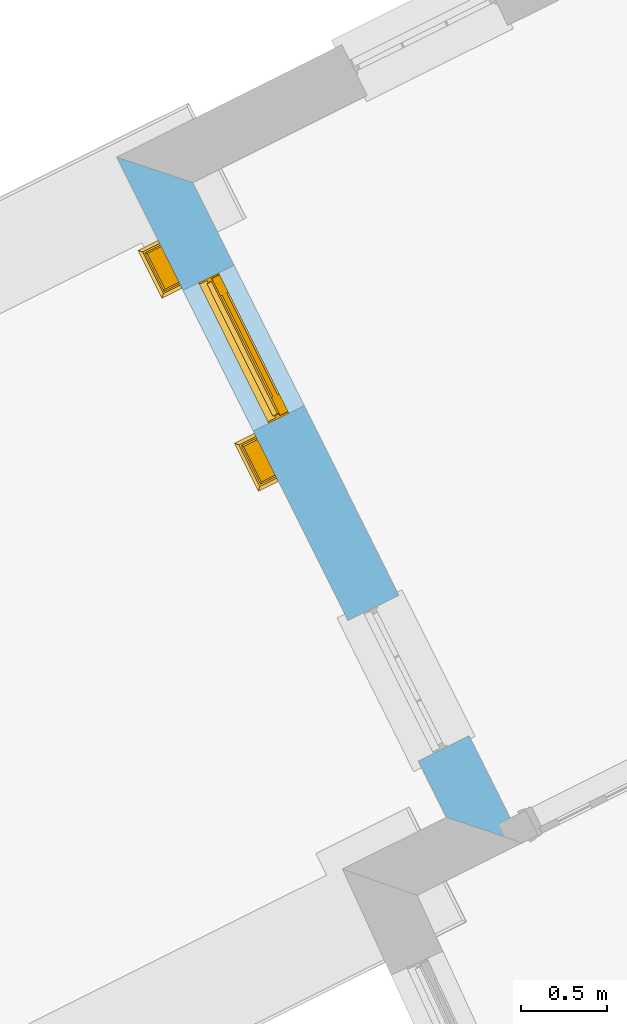
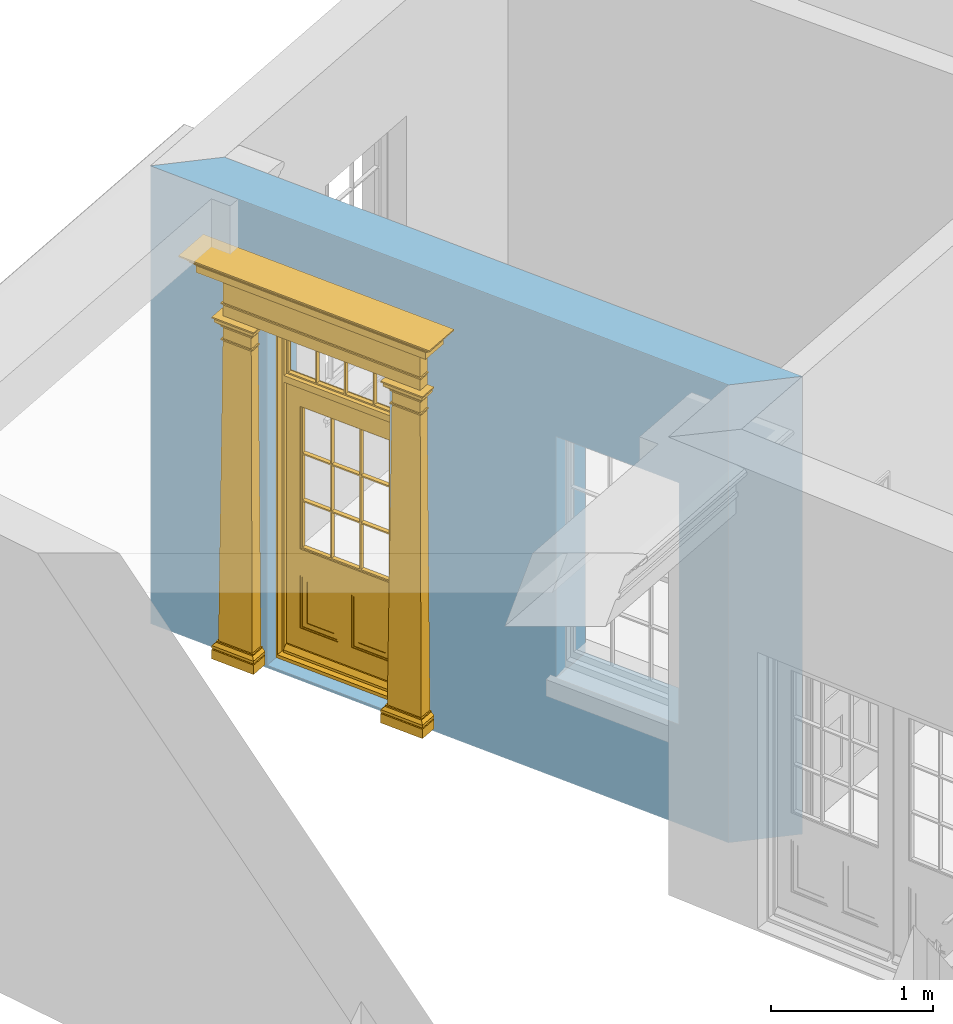
# One storey, part 7 of 10: 1 door, 2 openings, plus 1 element that does not belong to this part.
"""IFC2X3 building model written with IfcOpenShell, lengths in metres."""

import ifcopenshell
import ifcopenshell.guid

model = None  # the IFC model being written
_history = None  # IfcOwnerHistory: only IFC2X3 demands one
_inside = {}  # id of a spatial element -> (the spatial element, [elements in it])
_under = {}  # id of a project, library or spatial element -> (it, [spatial elements below it])
_declared = {}  # id of a project -> (the project, [libraries it declares])
_typed = {}  # id of a type object -> (the type object, [elements of that type])
_made_of = {}  # id of a material, layer set ... -> (it, [elements and type objects made of it])


def new_model(schema):
    """Start an empty IFC model of exactly this schema.

    Asked for "IFC4X3", IfcOpenShell would pick the latest addendum, in which some entities
    have other attributes; the version numbers below select the first issue.
    IFC2X3 requires an IfcOwnerHistory on every rooted entity: one is made here for all.
    """
    global model, _history
    if schema == "IFC4X3":
        model = ifcopenshell.file(schema_version=(4, 3, 0, 0))
    else:
        model = ifcopenshell.file(schema=schema)
    _inside.clear()
    _under.clear()
    _declared.clear()
    _typed.clear()
    _made_of.clear()
    _history = None
    if model.schema == "IFC2X3":
        org = make("IfcOrganization", Name="unknown")
        user = make(
            "IfcPersonAndOrganization",
            ThePerson=make("IfcPerson", FamilyName="unknown"),
            TheOrganization=org,
        )
        app = make(
            "IfcApplication",
            ApplicationDeveloper=org,
            Version="unknown",
            ApplicationFullName="unknown",
            ApplicationIdentifier="unknown",
        )
        _history = make(
            "IfcOwnerHistory",
            OwningUser=user,
            OwningApplication=app,
            ChangeAction="ADDED",
            CreationDate=0,
        )
    return model


def make(cls, **values):
    """One entity of the class cls with the attributes given. An attribute that is None is left unset."""
    return model.create_entity(
        cls, **{name: value for name, value in values.items() if value is not None}
    )


def rooted(cls, **values):
    """An entity with a GlobalId (a new one), such as an element, a storey or a relation."""
    return make(cls, GlobalId=ifcopenshell.guid.new(), OwnerHistory=_history, **values)


def si_unit(unit_type, name, prefix=None):
    """IfcSIUnit, for example si_unit("LENGTHUNIT", "METRE", prefix="MILLI")."""
    return make("IfcSIUnit", UnitType=unit_type, Prefix=prefix, Name=name)


def assignment(units):
    """IfcUnitAssignment: the units of a project."""
    return None if units is None else make("IfcUnitAssignment", Units=units)


def point(xyz):
    """IfcCartesianPoint."""
    return None if xyz is None else make("IfcCartesianPoint", Coordinates=xyz)


def direction(xyz):
    """IfcDirection."""
    return None if xyz is None else make("IfcDirection", DirectionRatios=xyz)


def frame(location, z_axis=None, x_axis=None):
    """IfcAxis2Placement3D, a coordinate frame: its origin and axes. An axis left out is left unset."""
    return make(
        "IfcAxis2Placement3D",
        Location=point(location),
        Axis=direction(z_axis),
        RefDirection=direction(x_axis),
    )


def origin():
    """The frame at (0, 0, 0) with its axes left unset."""
    return frame((0.0, 0.0, 0.0))


def place(relative_to, where):
    """IfcLocalPlacement: puts the frame where relative to a parent placement (None: the world)."""
    return make(
        "IfcLocalPlacement", PlacementRelTo=relative_to, RelativePlacement=where
    )


def context(
    kind, dimensions, precision=None, world=None, true_north=None, identifier=None
):
    """IfcGeometricRepresentationContext, for example the 3D "Model" context."""
    return make(
        "IfcGeometricRepresentationContext",
        ContextIdentifier=identifier,
        ContextType=kind,
        CoordinateSpaceDimension=dimensions,
        Precision=precision,
        WorldCoordinateSystem=world,
        TrueNorth=true_north,
    )


def subcontext(parent, identifier, kind, view, scale=None):
    """IfcGeometricRepresentationSubContext, for example "Body" below "Model"."""
    return make(
        "IfcGeometricRepresentationSubContext",
        ContextIdentifier=identifier,
        ContextType=kind,
        ParentContext=parent,
        TargetScale=scale,
        TargetView=view,
    )


def project(units=None, contexts=None):
    """IfcProject with its units and contexts."""
    return rooted(
        "IfcProject",
        Name="project",
        RepresentationContexts=contexts,
        UnitsInContext=assignment(units),
    )


def spatial(cls, under=None, at=None, **own):
    """A site, building, storey or space (cls), placed at a placement, below another one or the project."""
    s = rooted(cls, ObjectPlacement=at, **own)
    if under is not None:
        _under.setdefault(under.id(), (under, []))[1].append(s)
    return s


def polyline(points):
    """IfcPolyline through the points."""
    return make("IfcPolyline", Points=[point(p) for p in points])


def outline(outer, holes=None, kind="AREA"):
    """IfcArbitraryClosedProfileDef: a profile drawn as a closed curve; with holes, ...WithVoids."""
    if holes is None:
        return make("IfcArbitraryClosedProfileDef", ProfileType=kind, OuterCurve=outer)
    return make(
        "IfcArbitraryProfileDefWithVoids",
        ProfileType=kind,
        OuterCurve=outer,
        InnerCurves=holes,
    )


def extrude(swept, where, along, depth):
    """IfcExtrudedAreaSolid: the profile swept, set in the frame where, extruded along a direction by depth."""
    return make(
        "IfcExtrudedAreaSolid",
        SweptArea=swept,
        Position=where,
        ExtrudedDirection=direction(along),
        Depth=depth,
    )


def faces_of(points, faces, orient=None, outer=None):
    """IfcFace entities. A face is a list of loops; a loop is a list of indices into points, from 0.

    orient and outer hold one flag for each loop. By default every Orientation is true, the
    first loop of a face is its IfcFaceOuterBound and the others are IfcFaceBound.
    """
    made = []
    for i, loops in enumerate(faces):
        bounds = []
        for j, loop in enumerate(loops):
            is_outer = j == 0 if outer is None else outer[i][j]
            bounds.append(
                make(
                    "IfcFaceOuterBound" if is_outer else "IfcFaceBound",
                    Bound=make("IfcPolyLoop", Polygon=[points[k] for k in loop]),
                    Orientation=True if orient is None else orient[i][j],
                )
            )
        made.append(make("IfcFace", Bounds=bounds))
    return made


def faceted_brep(points, faces, orient=None, outer=None, voids=None):
    """IfcFacetedBrep: a solid bounded by flat faces; with voids (closed shells), ...WithVoids."""
    shared = [point(p) for p in points]
    hull = make("IfcClosedShell", CfsFaces=faces_of(shared, faces, orient, outer))
    if voids is None:
        return make("IfcFacetedBrep", Outer=hull)
    return make(
        "IfcFacetedBrepWithVoids",
        Outer=hull,
        Voids=[
            make(cls, CfsFaces=faces_of(shared, fs, o, b)) for cls, fs, o, b in voids
        ],
    )


def shape(context_of_items, identifier, shape_type, items):
    """IfcShapeRepresentation: the items that make up one representation, for example the "Body"."""
    return make(
        "IfcShapeRepresentation",
        ContextOfItems=context_of_items,
        RepresentationIdentifier=identifier,
        RepresentationType=shape_type,
        Items=items,
    )


def material(Name=None, Category=None):
    """IfcMaterial."""
    return make("IfcMaterial", Name=Name, Category=Category)


def layer(
    of_material, thickness, ventilated=None, Name=None, Category=None, Priority=None
):
    """IfcMaterialLayer: one layer of a wall or slab, of a material (None: an air gap)."""
    return make(
        "IfcMaterialLayer",
        Material=of_material,
        LayerThickness=thickness,
        IsVentilated=ventilated,
        Name=Name,
        Category=Category,
        Priority=Priority,
    )


def layer_set(layers, Name=None):
    """IfcMaterialLayerSet."""
    return make("IfcMaterialLayerSet", MaterialLayers=layers, LayerSetName=Name)


def layer_usage(for_layer_set, set_direction, sense, offset, extent=None):
    """IfcMaterialLayerSetUsage: how a layer set lies in its element."""
    return make(
        "IfcMaterialLayerSetUsage",
        ForLayerSet=for_layer_set,
        LayerSetDirection=set_direction,
        DirectionSense=sense,
        OffsetFromReferenceLine=offset,
        ReferenceExtent=extent,
    )


def made_of(thing, what):
    """Note that an element or type object is made of a material, layer set ...; save() writes the relation."""
    if what is not None:
        _made_of.setdefault(what.id(), (what, []))[1].append(thing)
    return thing


def element(
    cls,
    number,
    at=None,
    inside=None,
    cuts=None,
    type_object=None,
    material=None,
    context=None,
    identifier="Body",
    shape_type=None,
    held_by="IfcProductDefinitionShape",
    body=None,
    shapes=None,
    **own,
):
    """One element of the class cls, such as IfcWall. Its Tag is "e" and its number.

    at: its placement. inside: the storey or other place that contains it. cuts: it is an
    opening in that element (IfcRelVoidsElement). A single representation is given by context,
    identifier, shape_type and body (its items); several are given by shapes. held_by: the class
    of the entity that holds the representations. save() writes the other relations.
    """
    e = rooted(cls, Tag="e%d" % number, ObjectPlacement=at, **own)
    if body is not None:
        shapes = [shape(context, identifier, shape_type, body)]
    if shapes is not None:
        e.Representation = make(held_by, Representations=shapes)
    if inside is not None:
        _inside.setdefault(inside.id(), (inside, []))[1].append(e)
    if cuts is not None:
        rooted(
            "IfcRelVoidsElement", RelatingBuildingElement=cuts, RelatedOpeningElement=e
        )
    if type_object is not None:
        _typed.setdefault(type_object.id(), (type_object, []))[1].append(e)
    return made_of(e, material)


def fill(opening, filler):
    """IfcRelFillsElement: the door or window that sits in an opening."""
    return rooted(
        "IfcRelFillsElement",
        RelatingOpeningElement=opening,
        RelatedBuildingElement=filler,
    )


def aggregate(whole, parts):
    """IfcRelAggregates: a whole, such as a stair, and the parts it consists of."""
    return rooted("IfcRelAggregates", RelatingObject=whole, RelatedObjects=parts)


def save(model, path):
    """Write the relations noted so far, then the file.

    IfcRelAggregates (storeys below a building ...), IfcRelContainedInSpatialStructure (elements
    in a storey), IfcRelDefinesByType, IfcRelAssociatesMaterial and IfcRelDeclares: one each for
    every whole, place, type object, material and project.
    """
    for whole, parts in _under.values():
        aggregate(whole, parts)
    for where, things in _inside.values():
        rooted(
            "IfcRelContainedInSpatialStructure",
            RelatedElements=things,
            RelatingStructure=where,
        )
    for kind, things in _typed.values():
        rooted("IfcRelDefinesByType", RelatedObjects=things, RelatingType=kind)
    for what, things in _made_of.values():
        rooted("IfcRelAssociatesMaterial", RelatedObjects=things, RelatingMaterial=what)
    for by, libraries in _declared.values():
        rooted("IfcRelDeclares", RelatingContext=by, RelatedDefinitions=libraries)
    model.write(path)


model = new_model("IFC2X3")

# Units and contexts
model_context = context("Model", 3, world=origin())
body_context = subcontext(model_context, "Body", "Model", "MODEL_VIEW")
ifc_project = project(units=[si_unit("PLANEANGLEUNIT", "RADIAN"), si_unit("MASSUNIT", "GRAM", prefix="KILO"), si_unit("FORCEUNIT", "NEWTON", prefix="KILO"), si_unit("LENGTHUNIT", "METRE")], contexts=[model_context])

# Site, building, storey
site_placement = place(None, origin())
site = spatial("IfcSite", under=ifc_project, at=site_placement, CompositionType="ELEMENT")
building_placement = place(None, origin())
building = spatial("IfcBuilding", under=site, at=building_placement, Name="Building plot-8", CompositionType="ELEMENT")
storey_placement = place(None, origin())
storey = spatial("IfcBuildingStorey", under=building, at=storey_placement, Name="Floor 0", CompositionType="ELEMENT", Elevation=0.0)

# Wall, openings, door
ifc_material = material(Name="Masonry")
ifc_layer = layer(ifc_material, 0.33, ventilated=False)
ifc_layer_set = layer_set([ifc_layer], Name="My Wall")
ifc_layer_usage = layer_usage(ifc_layer_set, "AXIS2", "NEGATIVE", 0.08)
wall_placement = place(storey_placement, origin())
wall = element("IfcWallStandardCase", 1, at=wall_placement, inside=storey, material=ifc_layer_usage, Name="exterior", context=body_context, shape_type="SweptSolid", body=[
    extrude(outline(polyline([(22.6049906081901, 17.1432536383612), (22.162338538902, 17.2911020254168), (24.0721987779004, 13.4655957286817), (24.5148508471885, 13.3177473416261), (22.6049906081901, 17.1432536383612)])), origin(), (0.0, 0.0, 1.0), 3.45),
])
opening_1_placement = place(storey_placement, frame((0.0, 0.0, 0.02)))
opening_1 = element("IfcOpeningElement", 2, at=opening_1_placement, cuts=wall, Name="Opening", ObjectType="Opening", context=body_context, shape_type="SweptSolid", body=[
    extrude(outline(polyline([(22.5482357882612, 16.518138471764), (22.9547075319454, 15.7039636001386), (23.2499577601173, 15.8513654412549), (22.843486016433, 16.6655403128803), (22.5482357882612, 16.518138471764)])), origin(), (0.0, 0.0, 1.0), 2.545),
])
opening_2_placement = place(storey_placement, frame((0.0, 0.0, 0.75)))
element("IfcOpeningElement", 3, at=opening_2_placement, cuts=wall, Name="Opening", ObjectType="Opening", context=body_context, shape_type="SweptSolid", body=[
    extrude(outline(polyline([(23.5031659077604, 14.6053853233965), (23.9096376514446, 13.791210451771), (24.2048878796165, 13.9386122928873), (23.7984161359322, 14.7527871645127), (23.5031659077604, 14.6053853233965)])), origin(), (0.0, 0.0, 1.0), 1.82),
])
door_placement = place(storey_placement, frame((22.7719102035429, 16.6298065332157, 0.02), z_axis=(0.0, 0.0, 1.0), x_axis=(0.406471743684261, -0.814174871625426, 0.0)))
door = element("IfcDoor", 4, at=door_placement, inside=storey, Name="house entrance covered", OverallHeight=2.545, OverallWidth=0.91, context=body_context, shape_type="Brep", held_by="IfcProductRepresentation", body=[
    faceted_brep([(-0.305, -0.25, 2.895), (-0.335, -0.25, 2.915), (1.245, -0.25, 2.915), (1.215, -0.25, 2.895), (-0.315, -0.25, 2.895), (-0.335, -0.25, 2.925), (1.245, -0.25, 2.925), (1.225, -0.25, 2.895), (-0.295, -0.25, 2.885), (1.205, -0.25, 2.885), (-0.315, -0.37, 2.895), (-0.305, -0.36, 2.895), (-0.335, -0.39, 2.915), (-0.335, -0.39, 2.925), (-0.395, -0.25, 2.985), (1.305, -0.25, 2.985), (1.245, -0.39, 2.925), (1.245, -0.39, 2.915), (1.225, -0.37, 2.895), (1.215, -0.36, 2.895), (-0.305, -0.25, 2.885), (1.215, -0.25, 2.885), (-0.285, -0.25, 2.875), (1.195, -0.25, 2.875), (-0.305, -0.36, 2.885), (-0.395, -0.45, 2.925), (-0.395, -0.25, 2.925), (-0.405, -0.25, 2.995), (1.315, -0.25, 2.995), (1.305, -0.25, 2.925), (1.305, -0.45, 2.925), (1.215, -0.36, 2.885), (-0.295, -0.35, 2.885), (1.205, -0.35, 2.885), (-0.285, -0.34, 2.875), (1.195, -0.34, 2.875), (-0.275, -0.25, 2.865), (1.185, -0.25, 2.865), (-0.395, -0.45, 2.985), (-0.405, -0.25, 2.985), (-0.415, -0.25, 3.005), (1.325, -0.25, 3.005), (1.315, -0.25, 2.985), (1.305, -0.45, 2.985), (-0.285, -0.25, 2.865), (-0.285, -0.34, 2.865), (1.195, -0.34, 2.865), (1.195, -0.25, 2.865), (-0.275, -0.25, 2.675), (1.185, -0.25, 2.675), (-0.405, -0.46, 2.985), (-0.405, -0.46, 2.995), (-0.415, -0.47, 3.005), (-0.425, -0.25, 3.015), (1.335, -0.25, 3.015), (1.325, -0.47, 3.005), (1.315, -0.46, 2.995), (1.315, -0.46, 2.985), (-0.275, -0.33, 2.865), (1.185, -0.33, 2.865), (-0.275, -0.33, 2.675), (1.185, -0.33, 2.675), (-0.275, -0.25, 2.665), (1.185, -0.25, 2.665), (-0.425, -0.48, 3.005), (-0.425, -0.25, 3.005), (-0.445, -0.25, 3.046), (1.355, -0.25, 3.046), (1.335, -0.25, 3.005), (1.335, -0.48, 3.005), (-0.285, -0.34, 2.675), (-0.285, -0.25, 2.675), (1.195, -0.34, 2.675), (1.195, -0.25, 2.675), (-0.285, -0.25, 2.665), (1.195, -0.25, 2.665), (-0.015, -0.25, 2.575001), (0.925, -0.25, 2.575001), (-0.425, -0.48, 3.015), (-0.435, -0.25, 3.021), (-0.473, -0.25, 3.056), (1.383, -0.25, 3.056), (1.345, -0.25, 3.021), (1.335, -0.48, 3.015), (-0.285, -0.34, 2.665), (1.195, -0.34, 2.665), (-0.275, -0.33, 2.665), (1.185, -0.33, 2.665), (-0.275, -0.25, 2.575001), (1.185, -0.25, 2.575001), (-0.015, -0.33, 2.575001), (0.925, -0.33, 2.575001), (-0.435, -0.49, 3.021), (1.355, -0.5, 3.046), (-0.445, -0.5, 3.046), (1.345, -0.49, 3.021), (-0.473, -0.528, 3.056), (-0.473, -0.25, 3.066), (1.383, -0.25, 3.066), (1.383, -0.528, 3.056), (-0.275, -0.33, 2.575001), (1.185, -0.33, 2.575001), (-0.025, -0.25, 2.565001), (-0.315, -0.25, 2.565001), (1.225, -0.25, 2.565001), (0.935, -0.25, 2.565001), (-0.015, -0.38, 2.565001), (0.925, -0.25, 2.565001), (1.383, -0.528, 3.066), (-0.473, -0.528, 3.066), (-0.325, -0.25, 2.575001), (-0.325, -0.38, 2.575001), (1.235, -0.38, 2.575001), (1.235, -0.25, 2.575001), (-0.015, -0.25, 2.565001), (-0.035, -0.25, 2.535), (-0.305, -0.25, 2.535), (-0.325, -0.25, 2.565001), (1.235, -0.25, 2.565001), (0.945, -0.25, 2.535), (1.215, -0.25, 2.535), (-0.015, -0.38, 2.575001), (0.925, -0.38, 2.575001), (-0.325, -0.38, 2.565001), (1.235, -0.38, 2.565001), (-0.025, -0.37, 2.565001), (-0.025, -0.25, 2.535), (-0.305, -0.25, 2.525), (-0.035, -0.25, 2.525), (-0.315, -0.25, 2.535), (-0.315, -0.37, 2.565001), (1.225, -0.37, 2.565001), (0.935, -0.25, 2.535), (1.225, -0.25, 2.535), (1.215, -0.25, 2.525), (0.945, -0.25, 2.525), (0.935, -0.37, 2.565001), (0.925, -0.38, 2.565001), (-0.025, -0.37, 2.535), (-0.035, -0.36, 2.535), (-0.305, -0.36, 2.525), (-0.305, -0.36, 2.535), (-0.035, -0.36, 2.525), (-0.285, -0.25, 2.505), (-0.055, -0.25, 2.505), (-0.315, -0.37, 2.535), (1.225, -0.37, 2.535), (0.945, -0.36, 2.535), (0.935, -0.37, 2.535), (1.215, -0.36, 2.535), (1.215, -0.36, 2.525), (1.195, -0.25, 2.505), (0.965, -0.25, 2.505), (0.945, -0.36, 2.525), (-0.285, -0.34, 2.505), (-0.055, -0.34, 2.505), (-0.065, -0.25, 2.495), (-0.275, -0.25, 2.495), (1.195, -0.34, 2.505), (1.185, -0.25, 2.495), (0.975, -0.25, 2.495), (0.965, -0.34, 2.505), (-0.285, -0.25, 2.495), (-0.285, -0.34, 2.495), (-0.055, -0.25, 2.495), (-0.055, -0.34, 2.495), (-0.275, -0.25, 2.405), (-0.065, -0.25, 2.405), (1.195, -0.25, 2.495), (1.195, -0.34, 2.495), (1.185, -0.25, 2.405), (0.975, -0.25, 2.405), (0.965, -0.25, 2.495), (0.965, -0.34, 2.495), (-0.275, -0.33, 2.495), (-0.065, -0.33, 2.495), (-0.275, -0.33, 2.405), (-0.065, -0.33, 2.405), (-0.275, -0.25, 2.395), (-0.065, -0.25, 2.395), (1.185, -0.33, 2.495), (1.185, -0.33, 2.405), (1.185, -0.25, 2.395), (0.975, -0.25, 2.395), (0.975, -0.33, 2.405), (0.975, -0.33, 2.495), (-0.285, -0.25, 2.405), (-0.285, -0.34, 2.405), (-0.055, -0.34, 2.405), (-0.055, -0.25, 2.405), (-0.285, -0.25, 2.395), (-0.055, -0.25, 2.395), (-0.295, -0.25, 0.13), (-0.045, -0.25, 0.13), (1.195, -0.34, 2.405), (1.195, -0.25, 2.405), (1.195, -0.25, 2.395), (1.205, -0.25, 0.13), (0.955, -0.25, 0.13), (0.965, -0.25, 2.405), (0.965, -0.25, 2.395), (0.965, -0.34, 2.405), (-0.285, -0.34, 2.395), (-0.055, -0.34, 2.395), (-0.275, -0.33, 2.395), (-0.065, -0.33, 2.395), (-0.295, -0.35, 0.13), (-0.045, -0.35, 0.13), (-0.305, -0.25, 0.12), (-0.035, -0.25, 0.12), (1.195, -0.34, 2.395), (1.185, -0.33, 2.395), (1.205, -0.35, 0.13), (1.215, -0.25, 0.12), (0.945, -0.25, 0.12), (0.955, -0.35, 0.13), (0.975, -0.33, 2.395), (0.965, -0.34, 2.395), (-0.305, -0.25, 0.13), (-0.305, -0.36, 0.13), (-0.035, -0.25, 0.13), (-0.035, -0.36, 0.13), (-0.325, -0.25, 0.1), (-0.015, -0.25, 0.1), (1.215, -0.36, 0.13), (1.215, -0.25, 0.13), (1.235, -0.25, 0.1), (0.925, -0.25, 0.1), (0.945, -0.25, 0.13), (0.945, -0.36, 0.13), (-0.305, -0.36, 0.12), (-0.035, -0.36, 0.12), (-0.325, -0.38, 0.1), (-0.015, -0.38, 0.1), (-0.325, -0.25, 0.08), (-0.015, -0.25, 0.08), (1.215, -0.36, 0.12), (1.235, -0.38, 0.1), (1.235, -0.25, 0.08), (0.925, -0.25, 0.08), (0.925, -0.38, 0.1), (0.945, -0.36, 0.12), (-0.325, -0.38, 0.08), (-0.015, -0.38, 0.08), (-0.315, -0.25, 0.07), (-0.025, -0.25, 0.07), (1.235, -0.38, 0.08), (1.225, -0.25, 0.07), (0.935, -0.25, 0.07), (0.925, -0.38, 0.08), (-0.315, -0.37, 0.07), (-0.025, -0.37, 0.07), (-0.015, -0.25, 0.0), (-0.325, -0.25, 0.0), (1.225, -0.37, 0.07), (1.235, -0.25, 0.0), (0.925, -0.25, 0.0), (0.935, -0.37, 0.07), (-0.325, -0.25, 0.07), (-0.325, -0.38, 0.07), (-0.015, -0.38, 0.07), (-0.015, -0.25, 0.07), (-0.015, -0.38, 0.0), (-0.325, -0.38, 0.0), (1.235, -0.38, 0.07), (1.235, -0.25, 0.07), (1.235, -0.38, 0.0), (0.925, -0.38, 0.0), (0.925, -0.25, 0.07), (0.925, -0.38, 0.07), (0.885, -0.072, 0.025), (0.025, -0.072, 0.025), (0.025, -0.1, 0.025), (0.885, -0.1, 0.025), (0.9, -0.02, 0.025), (0.01, -0.02, 0.025), (0.9, -0.072, 0.025), (0.91, -0.02, 0.0), (0.0, -0.02, 0.0), (0.01, -0.072, 0.025), (0.9, -0.072, 2.07), (0.9, -0.02, 2.07), (0.885, -0.072, 2.055), (0.91, -0.02, 2.08), (0.01, -0.02, 2.07), (0.0, -0.02, 2.08), (0.01, -0.072, 2.07), (0.025, -0.072, 2.055), (0.455, -0.072, 2.07), (0.455, -0.02, 2.07), (0.455, -0.072, 2.055), (0.455, -0.02, 2.08), (0.455, -0.02, 2.105), (0.885, -0.02, 2.105), (0.025, -0.02, 2.105), (0.455, -0.04, 2.105), (0.885, -0.04, 2.105), (0.885, -0.02, 2.52), (0.91, -0.02, 2.545001), (0.025, -0.04, 2.105), (0.0, -0.02, 2.545001), (0.025, -0.02, 2.52), (0.885, -0.04, 2.52), (0.455, -0.02, 2.52), (0.455, -0.02, 2.545001), (0.025, -0.04, 2.52), (0.455, -0.04, 2.52), (0.0, -0.15, 0.0), (0.0, -0.15, 2.08), (0.91, -0.15, 0.0), (0.01, -0.15, 0.025), (0.01, -0.15, 2.08), (0.0, -0.15, 2.545001), (0.9, -0.15, 0.025), (0.91, -0.15, 2.08), (0.01, -0.1, 0.025), (0.01, -0.1, 2.055), (0.01, -0.15, 2.535), (0.455, -0.15, 2.545001), (0.9, -0.15, 2.08), (0.91, -0.15, 2.545001), (0.025, -0.1, 2.055), (0.01, -0.1, 2.105), (0.01, -0.1, 2.535), (0.455, -0.15, 2.535), (0.9, -0.1, 2.055), (0.9, -0.1, 0.025), (0.9, -0.15, 2.535), (0.025, -0.1, 2.105), (0.025, -0.1, 2.52), (0.455, -0.1, 2.535), (0.9, -0.1, 2.105), (0.885, -0.1, 2.055), (0.9, -0.1, 2.535), (0.455, -0.1, 2.055), (0.455, -0.1, 2.105), (0.025, -0.07, 2.105), (0.025, -0.07, 2.52), (0.455, -0.1, 2.52), (0.885, -0.1, 2.105), (0.885, -0.1, 2.52), (0.455, -0.07, 2.105), (0.035, -0.07, 2.51), (0.035, -0.07, 2.115), (0.455, -0.07, 2.52), (0.885, -0.07, 2.52), (0.885, -0.07, 2.105), (0.2475, -0.07, 2.115), (0.2375, -0.07, 2.115), (0.2375, -0.07, 2.51), (0.035, -0.04, 2.51), (0.035, -0.04, 2.115), (0.2475, -0.07, 2.51), (0.875, -0.07, 2.51), (0.875, -0.07, 2.115), (0.6725, -0.07, 2.115), (0.6625, -0.07, 2.115), (0.45, -0.07, 2.115), (0.2375, -0.04, 2.51), (0.2375, -0.04, 2.115), (0.45, -0.07, 2.51), (0.6625, -0.07, 2.51), (0.6725, -0.07, 2.51), (0.875, -0.04, 2.51), (0.875, -0.04, 2.115), (0.46, -0.07, 2.115), (0.45, -0.04, 2.115), (0.2475, -0.04, 2.115), (0.2475, -0.04, 2.51), (0.46, -0.07, 2.51), (0.45, -0.04, 2.51), (0.6725, -0.04, 2.51), (0.6725, -0.04, 2.115), (0.6625, -0.04, 2.51), (0.6625, -0.04, 2.115), (0.46, -0.04, 2.115), (0.46, -0.04, 2.51), (0.898, -0.07, 2.068), (0.898, -0.02, 2.068), (0.012, -0.02, 2.068), (0.012, -0.07, 2.068), (0.898, -0.07, 0.075), (0.898, -0.02, 0.027), (0.012, -0.02, 0.027), (0.012, -0.07, 0.075), (0.898, -0.07, 0.027), (0.012, -0.07, 0.027), (0.883, -0.07, 0.027), (0.883, -0.07, 0.075), (0.027, -0.07, 0.027), (0.027, -0.07, 0.075), (0.883, -0.08, 0.075), (0.883, -0.11, 0.045), (0.027, -0.11, 0.045), (0.027, -0.08, 0.075), (0.027, -0.11, 0.027), (0.883, -0.11, 0.027), (0.745, -0.05, 0.265), (0.545, -0.05, 0.265), (0.545, -0.055, 0.265), (0.745, -0.055, 0.265), (0.745, -0.05, 0.58), (0.545, -0.05, 0.58), (0.545, -0.055, 0.58), (0.515, -0.06, 0.235), (0.775, -0.06, 0.235), (0.745, -0.055, 0.58), (0.515, -0.06, 0.61), (0.515, -0.065, 0.235), (0.775, -0.065, 0.235), (0.775, -0.06, 0.61), (0.515, -0.065, 0.61), (0.785, -0.065, 0.225), (0.505, -0.065, 0.225), (0.775, -0.065, 0.61), (0.505, -0.065, 0.62), (0.785, -0.065, 0.62), (0.505, -0.07, 0.225), (0.785, -0.07, 0.225), (0.505, -0.07, 0.62), (0.785, -0.07, 0.62), (0.405, -0.07, 0.62), (0.405, -0.07, 0.225), (0.785, -0.07, 0.82), (0.125, -0.07, 0.82), (0.405, -0.065, 0.62), (0.405, -0.065, 0.225), (0.125, -0.07, 0.225), (0.785, -0.06, 0.82), (0.125, -0.06, 0.82), (0.125, -0.07, 0.62), (0.125, -0.065, 0.62), (0.395, -0.065, 0.61), (0.395, -0.065, 0.235), (0.125, -0.065, 0.225), (0.785, -0.07, 1.895), (0.558333, -0.06, 0.83), (0.351667, -0.06, 0.83), (0.125, -0.07, 1.895), (0.125, -0.06, 1.895), (0.785, -0.06, 1.895), (0.135, -0.065, 0.61), (0.395, -0.06, 0.61), (0.395, -0.06, 0.235), (0.135, -0.065, 0.235), (0.568333, -0.06, 0.83), (0.558333, -0.03, 0.83), (0.351667, -0.03, 0.83), (0.341667, -0.06, 0.83), (0.135, -0.06, 1.185), (0.135, -0.06, 1.53), (0.775, -0.06, 1.53), (0.775, -0.06, 1.185), (0.135, -0.06, 0.61), (0.365, -0.055, 0.58), (0.365, -0.055, 0.265), (0.135, -0.06, 0.235), (0.568333, -0.06, 1.175), (0.558333, -0.06, 1.175), (0.775, -0.06, 0.83), (0.558333, -0.03, 1.175), (0.785, -0.03, 0.82), (0.125, -0.03, 0.82), (0.351667, -0.03, 1.175), (0.351667, -0.06, 1.175), (0.341667, -0.06, 1.175), (0.135, -0.06, 0.83), (0.135, -0.06, 1.175), (0.135, -0.03, 1.185), (0.135, -0.03, 1.53), (0.135, -0.06, 1.54), (0.351667, -0.06, 1.885), (0.558333, -0.06, 1.885), (0.775, -0.03, 1.53), (0.775, -0.03, 1.185), (0.775, -0.06, 1.175), (0.775, -0.06, 1.54), (0.165, -0.055, 0.58), (0.365, -0.05, 0.58), (0.365, -0.05, 0.265), (0.165, -0.055, 0.265), (0.568333, -0.03, 0.83), (0.568333, -0.03, 1.175), (0.568333, -0.06, 1.185), (0.558333, -0.06, 1.185), (0.775, -0.03, 0.83), (0.785, -0.02, 0.82), (0.125, -0.02, 0.82), (0.341667, -0.03, 0.83), (0.341667, -0.03, 1.175), (0.351667, -0.06, 1.185), (0.341667, -0.06, 1.185), (0.135, -0.03, 0.83), (0.341667, -0.03, 1.185), (0.125, -0.03, 1.895), (0.341667, -0.03, 1.53), (0.341667, -0.06, 1.53), (0.135, -0.06, 1.885), (0.341667, -0.06, 1.54), (0.341667, -0.06, 1.885), (0.558333, -0.03, 1.885), (0.351667, -0.03, 1.885), (0.568333, -0.06, 1.885), (0.785, -0.03, 1.895), (0.568333, -0.03, 1.185), (0.568333, -0.06, 1.53), (0.568333, -0.03, 1.53), (0.568333, -0.06, 1.54), (0.775, -0.06, 1.885), (0.165, -0.05, 0.58), (0.165, -0.05, 0.265), (0.775, -0.03, 1.175), (0.558333, -0.06, 1.53), (0.351667, -0.03, 1.185), (0.558333, -0.03, 1.185), (0.505, -0.02, 0.62), (0.405, -0.02, 0.62), (0.125, -0.02, 1.895), (0.785, -0.02, 1.895), (0.351667, -0.06, 1.53), (0.135, -0.03, 1.175), (0.135, -0.03, 1.54), (0.341667, -0.03, 1.54), (0.135, -0.03, 1.885), (0.351667, -0.06, 1.54), (0.558333, -0.03, 1.54), (0.558333, -0.06, 1.54), (0.351667, -0.03, 1.54), (0.775, -0.03, 1.54), (0.568333, -0.03, 1.54), (0.775, -0.03, 1.885), (0.558333, -0.03, 1.53), (0.405, -0.02, 0.225), (0.505, -0.02, 0.225), (0.125, -0.02, 0.62), (0.785, -0.02, 0.62), (0.351667, -0.03, 1.53), (0.341667, -0.03, 1.885), (0.568333, -0.03, 1.885), (0.405, -0.025, 0.225), (0.405, -0.025, 0.62), (0.505, -0.025, 0.62), (0.505, -0.025, 0.225), (0.125, -0.025, 0.62), (0.785, -0.025, 0.62), (0.395, -0.025, 0.235), (0.395, -0.025, 0.61), (0.125, -0.02, 0.225), (0.125, -0.025, 0.225), (0.515, -0.025, 0.61), (0.515, -0.025, 0.235), (0.785, -0.02, 0.225), (0.785, -0.025, 0.225), (0.135, -0.025, 0.61), (0.775, -0.025, 0.61), (0.135, -0.025, 0.235), (0.395, -0.03, 0.235), (0.395, -0.03, 0.61), (0.515, -0.03, 0.61), (0.515, -0.03, 0.235), (0.775, -0.025, 0.235), (0.135, -0.03, 0.61), (0.775, -0.03, 0.61), (0.135, -0.03, 0.235), (0.365, -0.035, 0.265), (0.365, -0.035, 0.58), (0.545, -0.035, 0.58), (0.545, -0.035, 0.265), (0.775, -0.03, 0.235), (0.165, -0.035, 0.58), (0.745, -0.035, 0.58), (0.165, -0.035, 0.265), (0.365, -0.04, 0.58), (0.365, -0.04, 0.265), (0.545, -0.04, 0.58), (0.545, -0.04, 0.265), (0.745, -0.035, 0.265), (0.165, -0.04, 0.58), (0.745, -0.04, 0.58), (0.165, -0.04, 0.265), (0.745, -0.04, 0.265)], [[[0, 1, 2, 3]], [[0, 4, 1]], [[1, 5, 6, 2]], [[7, 3, 2]], [[8, 0, 3, 9]], [[10, 4, 0, 11]], [[12, 1, 4, 10]], [[1, 12, 13, 5]], [[5, 14, 15, 6]], [[6, 16, 17, 2]], [[7, 18, 19, 3]], [[2, 17, 18, 7]], [[8, 20, 0]], [[21, 9, 3]], [[22, 8, 9, 23]], [[11, 0, 20, 24]], [[10, 11, 19, 18]], [[12, 10, 18, 17]], [[25, 26, 5, 13]], [[13, 12, 17, 16]], [[5, 26, 14]], [[14, 27, 28, 15]], [[29, 6, 15]], [[29, 30, 16, 6]], [[3, 19, 31, 21]], [[24, 20, 8, 32]], [[21, 31, 33, 9]], [[32, 8, 22, 34]], [[9, 33, 35, 23]], [[36, 22, 23, 37]], [[11, 24, 31, 19]], [[38, 14, 26, 25]], [[25, 13, 16, 30]], [[14, 39, 27]], [[27, 40, 41, 28]], [[42, 15, 28]], [[15, 43, 30, 29]], [[24, 32, 33, 31]], [[34, 22, 44, 45]], [[32, 34, 35, 33]], [[23, 35, 46, 47]], [[36, 44, 22]], [[47, 37, 23]], [[48, 36, 37, 49]], [[50, 39, 14, 38]], [[38, 25, 30, 43]], [[51, 27, 39, 50]], [[52, 40, 27, 51]], [[40, 53, 54, 41]], [[41, 55, 56, 28]], [[42, 57, 43, 15]], [[28, 56, 57, 42]], [[45, 44, 36, 58]], [[34, 45, 46, 35]], [[47, 46, 59, 37]], [[60, 58, 36, 48]], [[59, 61, 49, 37]], [[62, 48, 49, 63]], [[50, 38, 43, 57]], [[51, 50, 57, 56]], [[64, 65, 40, 52]], [[52, 51, 56, 55]], [[40, 65, 53]], [[53, 66, 67, 54]], [[68, 41, 54]], [[68, 69, 55, 41]], [[45, 58, 59, 46]], [[58, 60, 61, 59]], [[70, 60, 48, 71]], [[61, 72, 73, 49]], [[71, 48, 62, 74]], [[49, 73, 75, 63]], [[76, 62, 63, 77]], [[78, 53, 65, 64]], [[64, 52, 55, 69]], [[53, 79, 66]], [[66, 80, 81, 67]], [[82, 54, 67]], [[54, 83, 69, 68]], [[60, 70, 72, 61]], [[84, 70, 71, 74]], [[72, 85, 75, 73]], [[86, 84, 74, 62]], [[85, 87, 63, 75]], [[76, 88, 62]], [[89, 77, 63]], [[90, 76, 77, 91]], [[92, 79, 53, 78]], [[93, 94, 92, 95]], [[64, 69, 83, 78]], [[94, 66, 79, 92]], [[80, 66, 94, 96]], [[80, 97, 98, 81]], [[99, 93, 67, 81]], [[82, 95, 83, 54]], [[67, 93, 95, 82]], [[92, 78, 83, 95]], [[70, 84, 85, 72]], [[84, 86, 87, 85]], [[100, 86, 62, 88]], [[87, 101, 89, 63]], [[88, 76, 102, 103]], [[77, 89, 104, 105]], [[76, 90, 106]], [[91, 77, 107]], [[86, 90, 91, 87]], [[108, 98, 97, 109]], [[109, 97, 80, 96]], [[98, 108, 99, 81]], [[86, 100, 90]], [[100, 88, 110, 111]], [[101, 87, 91]], [[89, 101, 112, 113]], [[76, 114, 102]], [[102, 115, 116, 103]], [[110, 88, 103, 117]], [[89, 113, 118, 104]], [[119, 105, 104, 120]], [[107, 77, 105]], [[90, 121, 106]], [[106, 114, 76]], [[107, 122, 91]], [[109, 96, 99, 108]], [[96, 94, 93, 99]], [[111, 121, 90, 100]], [[110, 117, 123, 111]], [[122, 112, 101, 91]], [[118, 113, 112, 124]], [[102, 114, 106, 125]], [[102, 126, 115]], [[127, 116, 115, 128]], [[103, 116, 129]], [[117, 103, 130, 123]], [[104, 118, 124, 131]], [[119, 132, 105]], [[104, 133, 120]], [[120, 134, 135, 119]], [[107, 105, 136, 137]], [[106, 121, 111, 123]], [[107, 137, 122]], [[122, 137, 124, 112]], [[130, 125, 106, 123]], [[126, 102, 125, 138]], [[115, 126, 138, 139]], [[116, 127, 140, 141]], [[128, 115, 139, 142]], [[143, 127, 128, 144]], [[129, 116, 141, 145]], [[103, 129, 145, 130]], [[136, 131, 124, 137]], [[133, 104, 131, 146]], [[132, 119, 147, 148]], [[105, 132, 148, 136]], [[120, 133, 146, 149]], [[134, 120, 149, 150]], [[134, 151, 152, 135]], [[119, 135, 153, 147]], [[138, 125, 130, 145]], [[141, 139, 138, 145]], [[127, 143, 154, 140]], [[142, 139, 141, 140]], [[144, 128, 142, 155]], [[156, 157, 143, 144]], [[136, 148, 146, 131]], [[147, 149, 146, 148]], [[147, 153, 150, 149]], [[151, 134, 150, 158]], [[159, 160, 152, 151]], [[135, 152, 161, 153]], [[143, 162, 163, 154]], [[140, 154, 155, 142]], [[164, 144, 155, 165]], [[166, 157, 156, 167]], [[157, 162, 143]], [[144, 164, 156]], [[158, 150, 153, 161]], [[168, 151, 158, 169]], [[159, 170, 171, 160]], [[172, 152, 160]], [[168, 159, 151]], [[152, 172, 173, 161]], [[174, 163, 162, 157]], [[155, 154, 163, 165]], [[164, 165, 175, 156]], [[157, 166, 176, 174]], [[167, 156, 175, 177]], [[178, 166, 167, 179]], [[158, 161, 173, 169]], [[169, 180, 159, 168]], [[170, 159, 180, 181]], [[170, 182, 183, 171]], [[160, 171, 184, 185]], [[173, 172, 160, 185]], [[174, 175, 165, 163]], [[186, 187, 176, 166]], [[174, 176, 177, 175]], [[177, 188, 189, 167]], [[178, 190, 186, 166]], [[167, 189, 191, 179]], [[192, 178, 179, 193]], [[185, 180, 169, 173]], [[181, 180, 185, 184]], [[194, 195, 170, 181]], [[196, 182, 170, 195]], [[182, 197, 198, 183]], [[199, 171, 183, 200]], [[201, 184, 171, 199]], [[190, 202, 187, 186]], [[177, 176, 187, 188]], [[191, 189, 188, 203]], [[204, 202, 190, 178]], [[191, 203, 205, 179]], [[178, 192, 206, 204]], [[193, 179, 205, 207]], [[208, 192, 193, 209]], [[181, 184, 201, 194]], [[210, 196, 195, 194]], [[210, 211, 182, 196]], [[211, 212, 197, 182]], [[197, 213, 214, 198]], [[183, 198, 215, 216]], [[217, 200, 183, 216]], [[199, 200, 217, 201]], [[202, 203, 188, 187]], [[204, 205, 203, 202]], [[192, 218, 219, 206]], [[204, 206, 207, 205]], [[220, 193, 207, 221]], [[208, 218, 192]], [[193, 220, 209]], [[222, 208, 209, 223]], [[217, 210, 194, 201]], [[216, 211, 210, 217]], [[212, 211, 216, 215]], [[212, 224, 225, 197]], [[225, 213, 197]], [[213, 226, 227, 214]], [[228, 198, 214]], [[198, 228, 229, 215]], [[218, 208, 230, 219]], [[221, 207, 206, 219]], [[209, 220, 221, 231]], [[208, 222, 232, 230]], [[223, 209, 231, 233]], [[234, 222, 223, 235]], [[224, 212, 215, 229]], [[213, 225, 224, 236]], [[226, 213, 236, 237]], [[226, 238, 239, 227]], [[214, 227, 240, 241]], [[228, 214, 241, 229]], [[231, 221, 219, 230]], [[234, 242, 232, 222]], [[233, 231, 230, 232]], [[235, 223, 233, 243]], [[244, 234, 235, 245]], [[229, 241, 236, 224]], [[241, 240, 237, 236]], [[246, 238, 226, 237]], [[238, 247, 248, 239]], [[227, 239, 249, 240]], [[234, 244, 250, 242]], [[243, 233, 232, 242]], [[245, 235, 243, 251]], [[252, 253, 244, 245]], [[240, 249, 246, 237]], [[247, 238, 246, 254]], [[255, 256, 248, 247]], [[239, 248, 257, 249]], [[258, 259, 250, 244]], [[242, 250, 251, 243]], [[251, 260, 261, 245]], [[262, 263, 253, 252]], [[253, 258, 244]], [[245, 261, 252]], [[254, 246, 249, 257]], [[264, 265, 247, 254]], [[266, 267, 256, 255]], [[268, 248, 256]], [[265, 255, 247]], [[269, 257, 248, 268]], [[258, 253, 263, 259]], [[251, 250, 259, 260]], [[252, 261, 260, 262]], [[259, 263, 262, 260]], [[254, 257, 269, 264]], [[255, 265, 264, 266]], [[266, 264, 269, 267]], [[268, 256, 267, 269]], [[270, 271, 272, 273]], [[271, 270, 274, 275]], [[276, 274, 270]], [[274, 277, 278, 275]], [[279, 271, 275]], [[280, 281, 274, 276]], [[276, 270, 282, 280]], [[281, 283, 277, 274]], [[284, 275, 278, 285]], [[286, 287, 271, 279]], [[275, 284, 286, 279]], [[280, 288, 289, 281]], [[282, 290, 288, 280]], [[281, 289, 291, 283]], [[285, 291, 289, 284]], [[286, 288, 290, 287]], [[284, 289, 288, 286]], [[283, 291, 292, 293]], [[294, 292, 291, 285]], [[293, 292, 295, 296]], [[283, 293, 297, 298]], [[299, 295, 292, 294]], [[294, 285, 300, 301]], [[296, 302, 297, 293]], [[297, 303, 304, 298]], [[305, 299, 294, 301]], [[300, 304, 303, 301]], [[302, 306, 303, 297]], [[301, 303, 306, 305]], [[285, 278, 307, 308]], [[309, 307, 278, 277]], [[307, 310, 311, 308]], [[285, 308, 312, 300]], [[307, 309, 313, 310]], [[314, 309, 277, 283]], [[315, 316, 311, 310]], [[312, 308, 311, 317]], [[312, 318, 304, 300]], [[319, 313, 309, 314]], [[310, 313, 273, 272]], [[320, 314, 283, 298]], [[272, 321, 316, 315]], [[322, 311, 316]], [[315, 310, 272]], [[317, 311, 322, 323]], [[317, 324, 318, 312]], [[298, 304, 318, 320]], [[313, 319, 325, 326]], [[327, 319, 314, 320]], [[326, 273, 313]], [[287, 321, 272, 271]], [[322, 316, 321, 328]], [[323, 322, 328, 329]], [[323, 330, 324, 317]], [[320, 318, 324, 327]], [[331, 325, 319]], [[326, 325, 332, 273]], [[333, 331, 319, 327]], [[287, 290, 334, 321]], [[321, 334, 335, 328]], [[336, 337, 329, 328]], [[329, 338, 330, 323]], [[327, 324, 330, 333]], [[339, 332, 325, 331]], [[282, 270, 273, 332]], [[340, 339, 331, 333]], [[332, 334, 290, 282]], [[339, 335, 334, 332]], [[328, 335, 341, 336]], [[342, 337, 336, 343]], [[337, 344, 338, 329]], [[333, 330, 338, 340]], [[339, 340, 345, 346]], [[346, 341, 335, 339]], [[341, 347, 348, 336]], [[342, 349, 337]], [[343, 336, 348]], [[350, 342, 343, 351]], [[349, 352, 344, 337]], [[340, 338, 344, 345]], [[346, 345, 353, 354]], [[355, 356, 341, 346]], [[357, 347, 341]], [[352, 349, 348, 347]], [[349, 342, 350, 358]], [[343, 348, 359, 351]], [[305, 350, 351, 299]], [[360, 344, 352]], [[345, 344, 361, 362]], [[353, 345, 362]], [[353, 363, 364, 354]], [[354, 355, 346]], [[362, 361, 356, 355]], [[365, 341, 356]], [[347, 357, 366, 367]], [[365, 357, 341]], [[358, 359, 348, 349]], [[367, 368, 352, 347]], [[350, 305, 358]], [[351, 359, 299]], [[360, 369, 344]], [[360, 352, 368, 370]], [[369, 361, 344]], [[362, 371, 363, 353]], [[302, 296, 364, 363]], [[372, 355, 354, 364]], [[373, 374, 356, 361]], [[372, 371, 362, 355]], [[365, 356, 374, 375]], [[370, 366, 357, 360]], [[366, 295, 367]], [[369, 360, 357, 365]], [[358, 368, 367, 359]], [[305, 306, 368, 358]], [[359, 367, 295, 299]], [[368, 306, 370]], [[361, 369, 376, 373]], [[363, 371, 302]], [[364, 296, 372]], [[373, 371, 372, 374]], [[374, 295, 375]], [[375, 376, 369, 365]], [[370, 376, 375, 366]], [[375, 295, 366]], [[370, 306, 376]], [[376, 306, 373]], [[371, 373, 306, 302]], [[296, 295, 374, 372]], [[377, 378, 379, 380]], [[381, 382, 378, 377]], [[383, 384, 380, 379]], [[385, 382, 381]], [[383, 386, 384]], [[382, 385, 387]], [[388, 387, 385, 381]], [[386, 383, 389]], [[384, 386, 389, 390]], [[383, 382, 387, 389]], [[391, 392, 387, 388]], [[390, 389, 393, 394]], [[395, 389, 387, 396]], [[396, 387, 392]], [[395, 393, 389]], [[397, 398, 399, 400]], [[397, 401, 402, 398]], [[402, 403, 399, 398]], [[400, 399, 404, 405]], [[406, 401, 397, 400]], [[406, 403, 402, 401]], [[399, 403, 407, 404]], [[405, 404, 408, 409]], [[405, 410, 406, 400]], [[410, 407, 403, 406]], [[404, 407, 411, 408]], [[412, 409, 408, 413]], [[409, 414, 410, 405]], [[414, 411, 407, 410]], [[415, 413, 408, 411]], [[412, 416, 414, 409]], [[412, 413, 417, 418]], [[411, 414, 416, 415]], [[413, 415, 419, 417]], [[418, 420, 416, 412]], [[388, 381, 418, 417]], [[420, 419, 415, 416]], [[417, 419, 421, 422]], [[420, 418, 381]], [[390, 388, 417, 422]], [[419, 420, 423]], [[423, 424, 421, 419]], [[422, 421, 425, 426]], [[420, 381, 377, 423]], [[394, 391, 388, 390]], [[390, 422, 427, 384]], [[428, 429, 424, 423]], [[421, 424, 430]], [[421, 430, 431, 425]], [[432, 433, 426, 425]], [[426, 434, 427, 422]], [[377, 435, 423]], [[393, 392, 391, 394]], [[427, 430, 384]], [[429, 428, 436, 437]], [[438, 424, 429, 439]], [[423, 435, 440, 428]], [[380, 384, 430, 424]], [[434, 431, 430, 427]], [[425, 431, 441, 432]], [[433, 432, 442, 443]], [[444, 434, 426, 433]], [[438, 435, 377, 380]], [[392, 393, 395, 396]], [[445, 436, 428]], [[437, 436, 446, 447]], [[437, 448, 429]], [[438, 380, 424]], [[439, 429, 449, 450]], [[435, 438, 439, 440]], [[451, 452, 428, 440]], [[444, 441, 431, 434]], [[432, 441, 453, 442]], [[443, 442, 454, 455]], [[443, 456, 444, 433]], [[445, 457, 458, 436]], [[445, 428, 459]], [[436, 458, 460, 446]], [[461, 462, 447, 446]], [[447, 463, 464, 437]], [[437, 464, 465, 448]], [[448, 466, 429]], [[467, 449, 429]], [[450, 449, 468, 469]], [[470, 439, 450]], [[440, 439, 471, 472]], [[473, 474, 452, 451]], [[475, 428, 452]], [[476, 451, 440]], [[456, 453, 441, 444]], [[442, 453, 477, 454]], [[454, 478, 479, 455]], [[455, 480, 456, 443]], [[481, 482, 457, 445]], [[458, 457, 483, 484]], [[459, 428, 475]], [[485, 481, 445, 459]], [[460, 458, 464, 463]], [[446, 460, 482, 481]], [[486, 487, 462, 461]], [[462, 488, 447]], [[481, 461, 446]], [[488, 489, 463, 447]], [[465, 464, 490, 491]], [[448, 465, 489, 488]], [[466, 448, 488, 492]], [[466, 467, 429]], [[491, 449, 467, 465]], [[491, 493, 468, 449]], [[469, 468, 462, 494]], [[495, 496, 450, 469]], [[497, 439, 470]], [[498, 470, 450, 496]], [[499, 471, 439]], [[500, 472, 471, 501]], [[502, 440, 472]], [[503, 461, 474, 473]], [[504, 483, 452, 474]], [[505, 506, 473, 451]], [[452, 483, 457, 475]], [[476, 507, 505, 451]], [[476, 440, 508]], [[480, 477, 453, 456]], [[454, 477, 509, 478]], [[479, 478, 509, 510]], [[479, 510, 480, 455]], [[457, 482, 511, 475]], [[512, 484, 483, 505]], [[484, 490, 464, 458]], [[459, 475, 511, 485]], [[481, 485, 461]], [[513, 514, 460, 463]], [[482, 460, 514, 504]], [[515, 516, 487, 486]], [[494, 462, 487, 517]], [[518, 486, 461, 503]], [[462, 492, 488]], [[463, 489, 493, 513]], [[496, 491, 490, 519]], [[489, 465, 467, 520]], [[492, 520, 467, 466]], [[495, 493, 491, 496]], [[489, 520, 468, 493]], [[468, 520, 462]], [[521, 469, 494]], [[495, 469, 521, 522]], [[499, 439, 497]], [[470, 521, 523, 497]], [[498, 522, 521, 470]], [[496, 519, 524, 498]], [[471, 499, 498, 524]], [[525, 526, 472, 500]], [[524, 527, 501, 471]], [[494, 503, 500, 501]], [[502, 508, 440]], [[502, 472, 526, 507]], [[511, 474, 461]], [[528, 503, 473]], [[505, 483, 504, 506]], [[504, 474, 511, 482]], [[529, 528, 473, 506]], [[529, 507, 476, 528]], [[512, 505, 507, 526]], [[528, 476, 508, 530]], [[509, 477, 480, 510]], [[531, 514, 484, 512]], [[484, 514, 513, 490]], [[485, 511, 461]], [[506, 504, 514, 531]], [[532, 516, 515, 533]], [[516, 534, 487]], [[515, 486, 535]], [[487, 379, 517]], [[503, 494, 517, 518]], [[486, 518, 378]], [[492, 462, 520]], [[536, 513, 493, 495]], [[519, 490, 513, 536]], [[494, 523, 521]], [[536, 495, 522, 527]], [[537, 499, 497, 523]], [[522, 498, 499, 537]], [[526, 524, 519, 512]], [[526, 525, 527, 524]], [[529, 525, 500, 538]], [[527, 522, 537, 501]], [[538, 500, 503]], [[501, 537, 494]], [[502, 538, 530, 508]], [[507, 529, 538, 502]], [[528, 530, 503]], [[506, 531, 525, 529]], [[531, 512, 519, 536]], [[539, 540, 516, 532]], [[533, 515, 541, 542]], [[533, 382, 383, 532]], [[540, 543, 534, 516]], [[383, 379, 487, 534]], [[486, 378, 382, 535]], [[544, 541, 515, 535]], [[379, 378, 518, 517]], [[537, 523, 494]], [[527, 525, 531, 536]], [[530, 538, 503]], [[540, 539, 545, 546]], [[532, 547, 548, 539]], [[549, 550, 542, 541]], [[551, 533, 542, 552]], [[533, 551, 382]], [[547, 532, 383]], [[553, 543, 540, 546]], [[547, 534, 543, 548]], [[547, 383, 534]], [[535, 382, 551]], [[544, 554, 549, 541]], [[552, 544, 535, 551]], [[555, 545, 539, 548]], [[556, 557, 546, 545]], [[550, 549, 558, 559]], [[552, 542, 550, 560]], [[548, 543, 553, 555]], [[557, 561, 553, 546]], [[560, 554, 544, 552]], [[562, 558, 549, 554]], [[545, 555, 563, 556]], [[564, 565, 557, 556]], [[559, 558, 566, 567]], [[560, 550, 559, 568]], [[555, 553, 561, 563]], [[565, 569, 561, 557]], [[568, 562, 554, 560]], [[570, 566, 558, 562]], [[556, 563, 571, 564]], [[572, 565, 564, 573]], [[566, 574, 575, 567]], [[568, 559, 567, 576]], [[563, 561, 569, 571]], [[572, 577, 569, 565]], [[576, 570, 562, 568]], [[578, 574, 566, 570]], [[564, 571, 579, 573]], [[579, 577, 572, 573]], [[575, 574, 578, 580]], [[576, 567, 575, 580]], [[569, 577, 579, 571]], [[578, 570, 576, 580]]]),
])
fill(opening_1, door)

save(model, "model.ifc")
